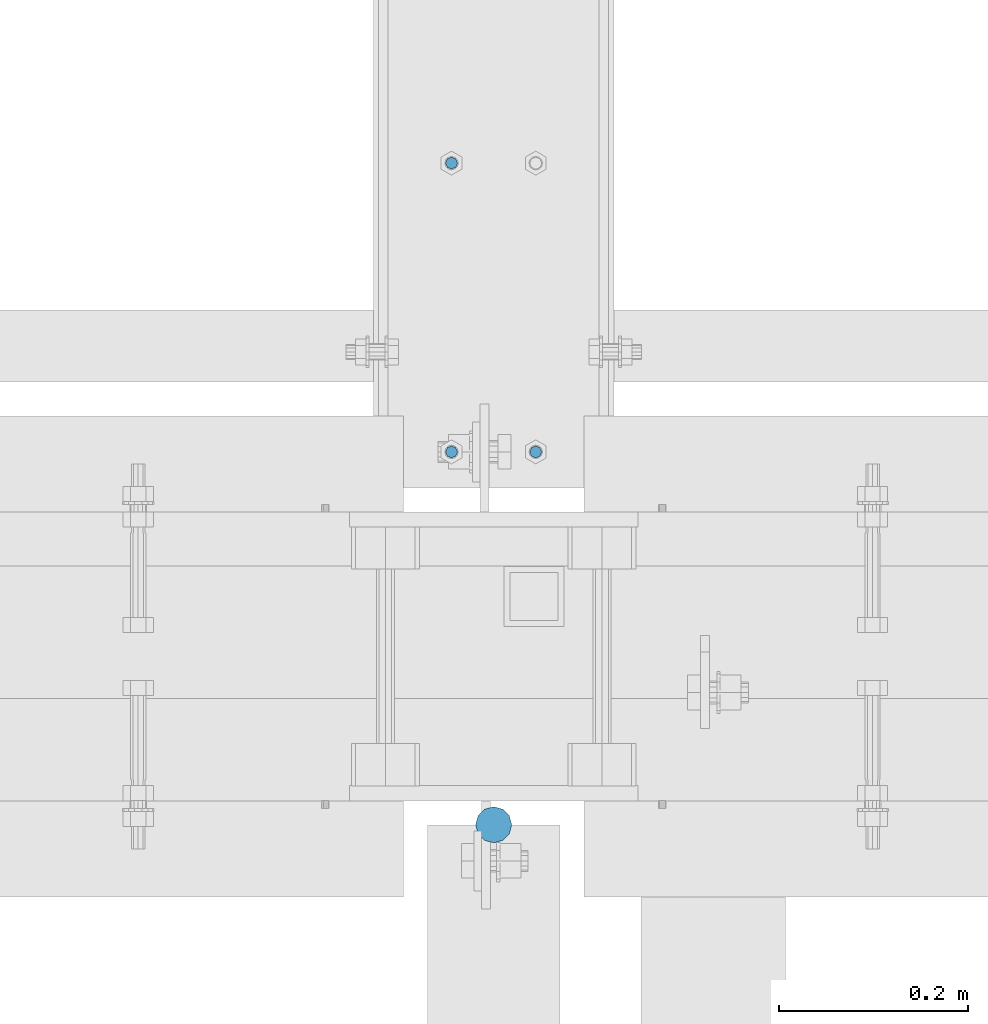
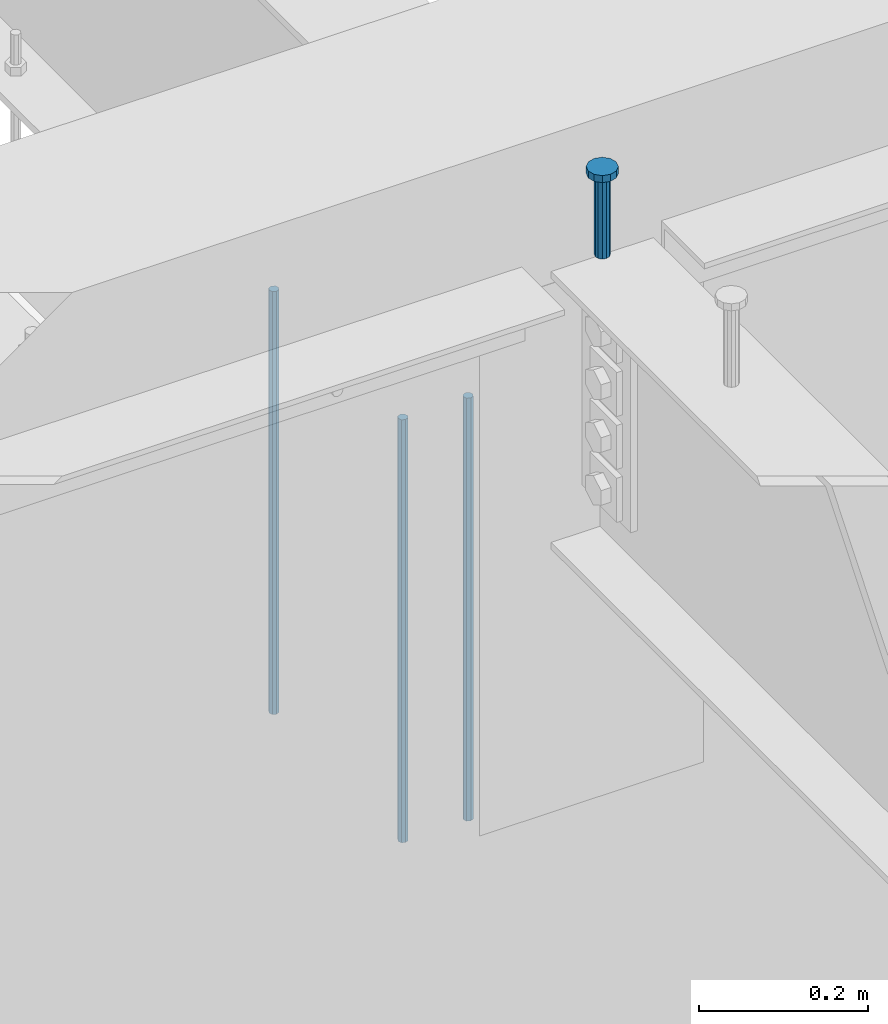
# One storey, part 221 of 975: 4 columns.
"""IFC2X3 building model written with IfcOpenShell, lengths in millimetres."""

from ifc_helpers import new_model, si_unit, frame, origin_with_axes, place, context, subcontext, project, spatial, faceted_brep, material, type_object, element, save


model = new_model("IFC2X3")

# Units and contexts
model_context = context("Model", 3, precision=1e-05, world=origin_with_axes())
body_context = subcontext(model_context, "Body", "Model", "MODEL_VIEW")
ifc_project = project(units=[si_unit("LENGTHUNIT", "METRE", prefix="MILLI"), si_unit("AREAUNIT", "SQUARE_METRE"), si_unit("VOLUMEUNIT", "CUBIC_METRE"), si_unit("MASSUNIT", "GRAM", prefix="KILO"), si_unit("TIMEUNIT", "SECOND"), si_unit("PLANEANGLEUNIT", "RADIAN"), si_unit("SOLIDANGLEUNIT", "STERADIAN"), si_unit("THERMODYNAMICTEMPERATUREUNIT", "DEGREE_CELSIUS"), si_unit("LUMINOUSINTENSITYUNIT", "LUMEN")], contexts=[model_context])

# Site, building, storey
site_placement = place(None, origin_with_axes())
site = spatial("IfcSite", under=ifc_project, at=site_placement, CompositionType="ELEMENT")
building_placement = place(site_placement, origin_with_axes())
building = spatial("IfcBuilding", under=site, at=building_placement, Name="Undefined", CompositionType="ELEMENT")
storey_placement = place(building_placement, origin_with_axes())
storey = spatial("IfcBuildingStorey", under=building, at=storey_placement, Name="Undefined", CompositionType="ELEMENT", Elevation=0.0)

# Columns
ifc_material_1 = material(Name="STEEL/A36")
column_type_1 = type_object("IfcColumnType", PredefinedType="NOTDEFINED")
for number, where, z_axis, x_axis, name in (
    (1, (8185.15, 21116.925, 2870.2), (-0.999999999999998, 6.90000001668524e-08, 0.0), (0.0, 0.0, 1.0), "ALL-THREAD ROD"),
    (2, (8274.05, 20812.125, 2870.2), (-0.999999999999998, 6.90000001668524e-08, 0.0), (0.0, 0.0, 1.0), "ALL-THREAD ROD"),
    (3, (8185.15, 20812.125, 2870.2), (-0.999999999999998, 6.90000001668524e-08, 0.0), (0.0, 0.0, 1.0), "ALL-THREAD ROD"),
):
    element("IfcColumn", number, at=place(storey_placement, frame(where, z_axis=z_axis, x_axis=x_axis)), inside=storey, type_object=column_type_1, material=ifc_material_1, Name=name, context=body_context, shape_type="Brep", body=[
        faceted_brep([(0.0, -6.34999999998763, -3.63797880709171e-12), (0.0, -4.49012806052269, -4.49012806054634), (609.6, -4.49012806053361, -4.49012806053543), (609.6, -6.34999999999854, 0.0), (0.0, 7.27595761418343e-12, -6.35000000000764), (609.6, 0.0, -6.35000000000036), (0.0, 4.49012806053724, -4.49012806053906), (609.6, 4.49012806053361, -4.49012806053543), (0.0, 6.34999999999491, 5.45696821063757e-12), (609.6, 6.34999999999854, 0.0), (0.0, 4.49012806052633, 4.49012806054634), (609.6, 4.49012806053361, 4.49012806053543), (0.0, 0.0, 6.35000000000764), (609.6, 0.0, 6.35000000000036), (0.0, -4.49012806053361, 4.49012806053543), (609.6, -4.49012806053361, 4.49012806053543)], [[[0, 1, 2, 3]], [[1, 4, 5, 2]], [[4, 6, 7, 5]], [[6, 8, 9, 7]], [[8, 10, 11, 9]], [[10, 12, 13, 11]], [[12, 14, 15, 13]], [[14, 0, 3, 15]], [[5, 7, 9, 11, 13, 15, 3, 2]], [[14, 12, 10, 8, 6, 4, 1, 0]]]),
    ])
ifc_material_2 = material(Name="STEEL/A108")
column_type_2 = type_object("IfcColumnType", Name="STUD_3/4-DIA", PredefinedType="NOTDEFINED")
column_placement = place(storey_placement, frame((8229.66627141015, 20418.425, 3937.0), z_axis=(0.0, 1.0, 0.0), x_axis=(0.0, 0.0, 1.0)))
element("IfcColumn", 4, at=column_placement, inside=storey, type_object=column_type_2, material=ifc_material_2, ObjectType="STUD_3/4-DIA", context=body_context, shape_type="Brep", body=[
    faceted_brep([(0.0, -9.52000045776367, 0.0), (0.0, -8.25, -4.76000022888184), (115.57, -8.25, -4.76000022888184), (115.57, -9.52000045776367, 0.0), (0.0, -4.76000022888184, -8.25), (115.57, -4.76000022888184, -8.25), (0.0, 0.0, -9.52000045776367), (115.57, 0.0, -9.52000045776367), (0.0, 4.76000022888184, -8.25), (115.57, 4.76000022888184, -8.25), (0.0, 8.25, -4.76000022888184), (115.57, 8.25, -4.76000022888184), (0.0, 9.52000045776367, 0.0), (115.57, 9.52000045776367, 0.0), (0.0, 8.25, 4.76000022888184), (115.57, 8.25, 4.76000022888184), (0.0, 4.76000022888184, 8.25), (115.57, 4.76000022888184, 8.25), (0.0, 0.0, 9.52000045776367), (115.57, 0.0, 9.52000045776367), (0.0, -4.76000022888184, 8.25), (115.57, -4.76000022888184, 8.25), (0.0, -8.25, 4.76000022888184), (115.57, -8.25, 4.76000022888184), (116.84, -16.5, -9.52000045776367), (116.84, -19.0499992370605, 0.0), (116.84, -9.52000045776367, -16.5), (116.84, 0.0, -19.0499992370605), (116.84, 9.52000045776367, -16.5), (116.84, 16.5, -9.52000045776367), (116.84, 19.0499992370605, 0.0), (116.84, 16.5, 9.52000045776367), (116.84, 9.52000045776367, 16.5), (116.84, 0.0, 19.0499992370605), (116.84, -9.52000045776367, 16.5), (116.84, -16.5, 9.52000045776367), (127.0, -16.5, -9.52000045776367), (127.0, -19.0499992370605, 0.0), (127.0, -9.52000045776367, -16.5), (127.0, 0.0, -19.0499992370605), (127.0, 9.52000045776367, -16.5), (127.0, 16.5, -9.52000045776367), (127.0, 19.0499992370605, 0.0), (127.0, 16.5, 9.52000045776367), (127.0, 9.52000045776367, 16.5), (127.0, 0.0, 19.0499992370605), (127.0, -9.52000045776367, 16.5), (127.0, -16.5, 9.52000045776367)], [[[0, 1, 2, 3]], [[1, 4, 5, 2]], [[4, 6, 7, 5]], [[6, 8, 9, 7]], [[8, 10, 11, 9]], [[10, 12, 13, 11]], [[12, 14, 15, 13]], [[14, 16, 17, 15]], [[16, 18, 19, 17]], [[18, 20, 21, 19]], [[20, 22, 23, 21]], [[22, 0, 3, 23]], [[22, 20, 18, 16, 14, 12, 10, 8, 6, 4, 1, 0]], [[3, 2, 24, 25]], [[2, 5, 26, 24]], [[5, 7, 27, 26]], [[7, 9, 28, 27]], [[9, 11, 29, 28]], [[11, 13, 30, 29]], [[13, 15, 31, 30]], [[15, 17, 32, 31]], [[17, 19, 33, 32]], [[19, 21, 34, 33]], [[21, 23, 35, 34]], [[23, 3, 25, 35]], [[25, 24, 36, 37]], [[24, 26, 38, 36]], [[26, 27, 39, 38]], [[27, 28, 40, 39]], [[28, 29, 41, 40]], [[29, 30, 42, 41]], [[30, 31, 43, 42]], [[31, 32, 44, 43]], [[32, 33, 45, 44]], [[33, 34, 46, 45]], [[34, 35, 47, 46]], [[35, 25, 37, 47]], [[38, 39, 40, 41, 42, 43, 44, 45, 46, 47, 37, 36]]]),
])

save(model, "model.ifc")
